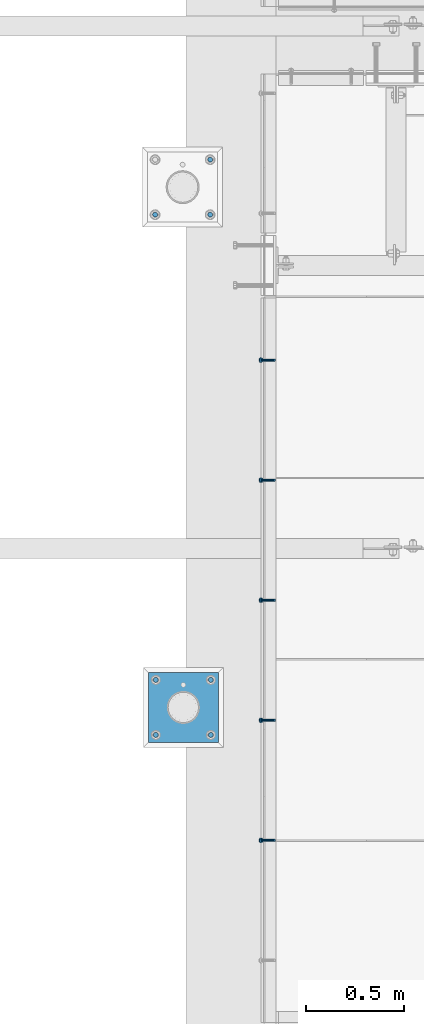
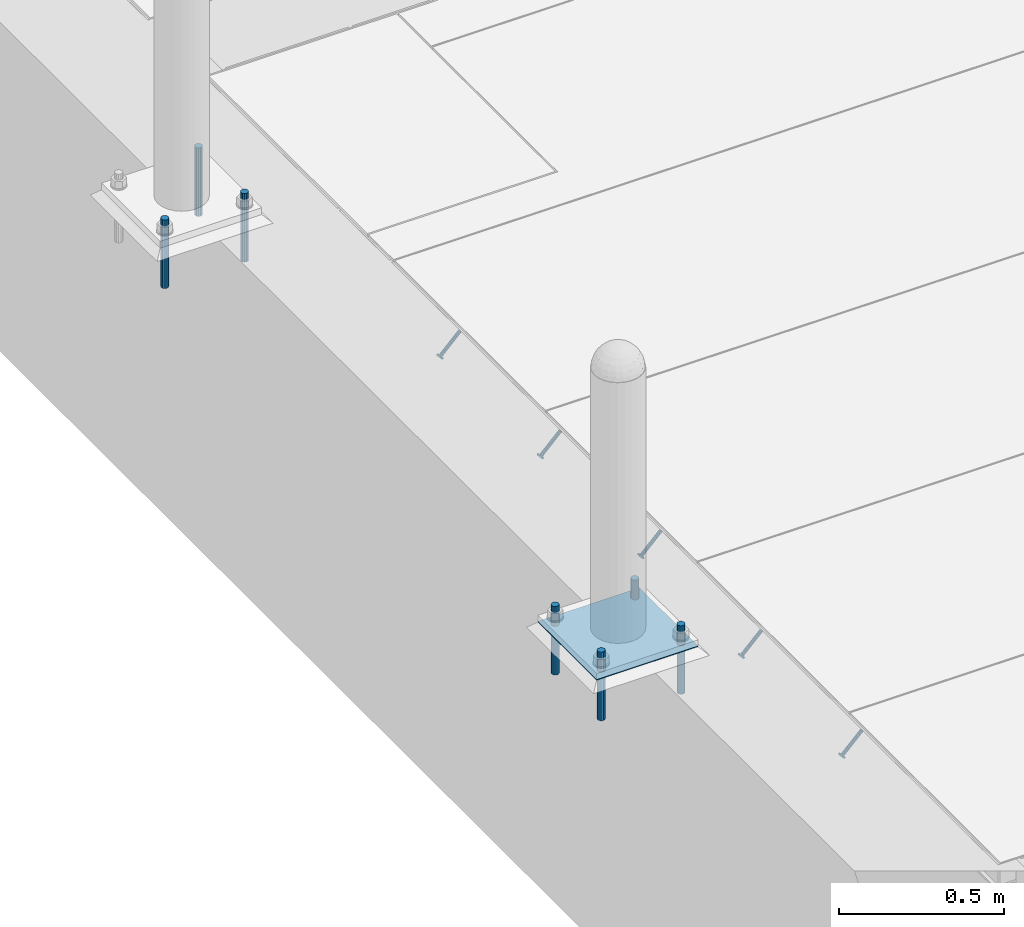
# One storey, part 2005 of 3843: 8 beams, 5 members, 3 elements without a shape of their own.
"""IFC2X3 building model written with IfcOpenShell, lengths in millimetres."""

from ifc_helpers import new_model, si_unit, frame, origin_with_axes, place, context, subcontext, project, spatial, faceted_brep, material, type_object, element, aggregate, save


model = new_model("IFC2X3")

# Units and contexts
model_context = context("Model", 3, precision=1e-05, world=origin_with_axes())
body_context = subcontext(model_context, "Body", "Model", "MODEL_VIEW")
ifc_project = project(units=[si_unit("LENGTHUNIT", "METRE", prefix="MILLI"), si_unit("AREAUNIT", "SQUARE_METRE"), si_unit("VOLUMEUNIT", "CUBIC_METRE"), si_unit("MASSUNIT", "GRAM", prefix="KILO"), si_unit("TIMEUNIT", "SECOND"), si_unit("PLANEANGLEUNIT", "RADIAN"), si_unit("SOLIDANGLEUNIT", "STERADIAN"), si_unit("THERMODYNAMICTEMPERATUREUNIT", "DEGREE_CELSIUS"), si_unit("LUMINOUSINTENSITYUNIT", "LUMEN")], contexts=[model_context])

# Site, building, storey
site_placement = place(None, origin_with_axes())
site = spatial("IfcSite", under=ifc_project, at=site_placement, CompositionType="ELEMENT")
building_placement = place(site_placement, origin_with_axes())
building = spatial("IfcBuilding", under=site, at=building_placement, Name="Undefined", CompositionType="ELEMENT")
storey_placement = place(building_placement, origin_with_axes())
storey = spatial("IfcBuildingStorey", under=building, at=storey_placement, Name="Undefined", CompositionType="ELEMENT", Elevation=0.0)

# Assembly, members
assembly_1_placement = place(storey_placement, origin_with_axes())
assembly_1 = element("IfcElementAssembly", 1, at=assembly_1_placement, inside=storey, Name="ANGLE", AssemblyPlace="NOTDEFINED", PredefinedType="RIGID_FRAME")
ifc_material_1 = material(Name="STEEL/A108")
member_type = type_object("IfcMemberType", PredefinedType="NOTDEFINED")
member_1_placement = place(assembly_1_placement, frame((41411.525, 16171.8625, 30397.4500030518), z_axis=(0.0, -1.0, 0.0), x_axis=(-0.707106781186548, 0.0, -0.707106781186548)))
member_1 = element("IfcMember", 2, at=member_1_placement, type_object=member_type, material=ifc_material_1, Name="HEADED STUD ANCHOR", context=body_context, shape_type="Brep", body=[
    faceted_brep([(7.27595761418343e-12, -3.18000006675175, 5.5), (0.0, -5.49999999998363, 3.1800000667572), (94.4879985803855, -5.50000000011278, 3.1800000667572), (94.4879985803782, -3.18000006687362, 5.5), (0.0, -6.3499999046162, 0.0), (94.4879985803855, -6.34999990474535, 0.0), (0.0, -5.49999999998363, -3.1800000667572), (94.4879985803855, -5.50000000011278, -3.1800000667572), (7.27595761418343e-12, -3.18000006675175, -5.5), (94.4879985803782, -3.18000006687362, -5.5), (7.27595761418343e-12, -1.81898940354586e-12, -6.34999990463257), (94.4879985803782, -1.20053300634027e-10, -6.34999990463257), (0.0, 3.18000006675175, -5.5), (94.4879985803709, 3.18000006663351, -5.5), (7.27595761418343e-12, 5.49999999998363, -3.1800000667572), (94.4879985803709, 5.49999999987267, -3.1800000667572), (7.27595761418343e-12, 6.3499999046162, 0.0), (94.4879985803673, 6.34999990450706, 0.0), (7.27595761418343e-12, 5.49999999998363, 3.1800000667572), (94.4879985803709, 5.49999999987267, 3.1800000667572), (0.0, 3.18000006675175, 5.5), (94.4879985803709, 3.18000006663351, 5.5), (7.27595761418343e-12, -1.81898940354586e-12, 6.34999990463257), (94.4879985803782, -1.20053300634027e-10, 6.34999990463257), (96.5199985498621, -10.9899997712273, 6.34999990463257), (96.5199985498548, -6.34000015270249, 10.9899997711182), (96.5199985498621, -12.6999998093743, 0.0), (96.5199985498621, -10.9899997712273, -6.34999990463257), (96.5199985498548, -6.34000015270249, -10.9899997711182), (96.5199985498475, -1.21872290037572e-10, -12.6899995803833), (96.5199985498402, 6.34000015245874, -10.9899997711182), (96.519998549833, 10.9899997709817, -6.34999990463257), (96.519998549833, 12.6999998091305, 0.0), (96.519998549833, 10.9899997709817, 6.34999990463257), (96.5199985498402, 6.34000015245874, 10.9899997711182), (96.5199985498475, -1.21872290037572e-10, 12.6899995803833), (101.599998473539, -10.9899997712328, 6.34999990463257), (101.599998473532, -6.34000015270976, 10.9899997711182), (101.599998473539, -12.6999998093797, 0.0), (101.599998473539, -10.9899997712328, -6.34999990463257), (101.599998473532, -6.34000015270976, -10.9899997711182), (101.599998473524, -1.29148247651756e-10, -12.6899995803833), (101.599998473517, 6.34000015245329, -10.9899997711182), (101.59999847351, 10.9899997709763, -6.34999990463257), (101.599998473503, 12.6999998091196, 0.0), (101.59999847351, 10.9899997709763, 6.34999990463257), (101.599998473517, 6.34000015245329, 10.9899997711182), (101.599998473524, -1.29148247651756e-10, 12.6899995803833)], [[[0, 1, 2, 3]], [[1, 4, 5, 2]], [[4, 6, 7, 5]], [[6, 8, 9, 7]], [[8, 10, 11, 9]], [[10, 12, 13, 11]], [[12, 14, 15, 13]], [[14, 16, 17, 15]], [[16, 18, 19, 17]], [[18, 20, 21, 19]], [[20, 22, 23, 21]], [[22, 0, 3, 23]], [[22, 20, 18, 16, 14, 12, 10, 8, 6, 4, 1, 0]], [[3, 2, 24, 25]], [[2, 5, 26, 24]], [[5, 7, 27, 26]], [[7, 9, 28, 27]], [[9, 11, 29, 28]], [[11, 13, 30, 29]], [[13, 15, 31, 30]], [[15, 17, 32, 31]], [[17, 19, 33, 32]], [[19, 21, 34, 33]], [[21, 23, 35, 34]], [[23, 3, 25, 35]], [[25, 24, 36, 37]], [[24, 26, 38, 36]], [[26, 27, 39, 38]], [[27, 28, 40, 39]], [[28, 29, 41, 40]], [[29, 30, 42, 41]], [[30, 31, 43, 42]], [[31, 32, 44, 43]], [[32, 33, 45, 44]], [[33, 34, 46, 45]], [[34, 35, 47, 46]], [[35, 25, 37, 47]], [[38, 39, 40, 41, 42, 43, 44, 45, 46, 47, 37, 36]]]),
])
member_2_placement = place(assembly_1_placement, frame((41411.525, 16781.4625, 30397.4500030518), z_axis=(0.0, -1.0, 0.0), x_axis=(-0.707106781186548, 0.0, -0.707106781186548)))
member_2 = element("IfcMember", 3, at=member_2_placement, type_object=member_type, material=ifc_material_1, Name="HEADED STUD ANCHOR", context=body_context, shape_type="Brep", body=[
    faceted_brep([(7.27595761418343e-12, -3.18000006675175, 5.5), (0.0, -5.49999999998363, 3.1800000667572), (94.4879985803855, -5.50000000011278, 3.1800000667572), (94.4879985803782, -3.18000006687362, 5.5), (0.0, -6.3499999046162, 0.0), (94.4879985803855, -6.34999990474535, 0.0), (0.0, -5.49999999998363, -3.1800000667572), (94.4879985803855, -5.50000000011278, -3.1800000667572), (7.27595761418343e-12, -3.18000006675175, -5.5), (94.4879985803782, -3.18000006687362, -5.5), (7.27595761418343e-12, -1.81898940354586e-12, -6.34999990463257), (94.4879985803782, -1.20053300634027e-10, -6.34999990463257), (0.0, 3.18000006675175, -5.5), (94.4879985803709, 3.18000006663351, -5.5), (7.27595761418343e-12, 5.49999999998363, -3.1800000667572), (94.4879985803709, 5.49999999987267, -3.1800000667572), (7.27595761418343e-12, 6.3499999046162, 0.0), (94.4879985803673, 6.34999990450706, 0.0), (7.27595761418343e-12, 5.49999999998363, 3.1800000667572), (94.4879985803709, 5.49999999987267, 3.1800000667572), (0.0, 3.18000006675175, 5.5), (94.4879985803709, 3.18000006663351, 5.5), (7.27595761418343e-12, -1.81898940354586e-12, 6.34999990463257), (94.4879985803782, -1.20053300634027e-10, 6.34999990463257), (96.5199985498621, -10.9899997712273, 6.34999990463257), (96.5199985498548, -6.34000015270249, 10.9899997711182), (96.5199985498621, -12.6999998093743, 0.0), (96.5199985498621, -10.9899997712273, -6.34999990463257), (96.5199985498548, -6.34000015270249, -10.9899997711182), (96.5199985498475, -1.21872290037572e-10, -12.6899995803833), (96.5199985498402, 6.34000015245874, -10.9899997711182), (96.519998549833, 10.9899997709817, -6.34999990463257), (96.519998549833, 12.6999998091305, 0.0), (96.519998549833, 10.9899997709817, 6.34999990463257), (96.5199985498402, 6.34000015245874, 10.9899997711182), (96.5199985498475, -1.21872290037572e-10, 12.6899995803833), (101.599998473539, -10.9899997712328, 6.34999990463257), (101.599998473532, -6.34000015270976, 10.9899997711182), (101.599998473539, -12.6999998093797, 0.0), (101.599998473539, -10.9899997712328, -6.34999990463257), (101.599998473532, -6.34000015270976, -10.9899997711182), (101.599998473524, -1.29148247651756e-10, -12.6899995803833), (101.599998473517, 6.34000015245329, -10.9899997711182), (101.59999847351, 10.9899997709763, -6.34999990463257), (101.599998473503, 12.6999998091196, 0.0), (101.59999847351, 10.9899997709763, 6.34999990463257), (101.599998473517, 6.34000015245329, 10.9899997711182), (101.599998473524, -1.29148247651756e-10, 12.6899995803833)], [[[0, 1, 2, 3]], [[1, 4, 5, 2]], [[4, 6, 7, 5]], [[6, 8, 9, 7]], [[8, 10, 11, 9]], [[10, 12, 13, 11]], [[12, 14, 15, 13]], [[14, 16, 17, 15]], [[16, 18, 19, 17]], [[18, 20, 21, 19]], [[20, 22, 23, 21]], [[22, 0, 3, 23]], [[22, 20, 18, 16, 14, 12, 10, 8, 6, 4, 1, 0]], [[3, 2, 24, 25]], [[2, 5, 26, 24]], [[5, 7, 27, 26]], [[7, 9, 28, 27]], [[9, 11, 29, 28]], [[11, 13, 30, 29]], [[13, 15, 31, 30]], [[15, 17, 32, 31]], [[17, 19, 33, 32]], [[19, 21, 34, 33]], [[21, 23, 35, 34]], [[23, 3, 25, 35]], [[25, 24, 36, 37]], [[24, 26, 38, 36]], [[26, 27, 39, 38]], [[27, 28, 40, 39]], [[28, 29, 41, 40]], [[29, 30, 42, 41]], [[30, 31, 43, 42]], [[31, 32, 44, 43]], [[32, 33, 45, 44]], [[33, 34, 46, 45]], [[34, 35, 47, 46]], [[35, 25, 37, 47]], [[38, 39, 40, 41, 42, 43, 44, 45, 46, 47, 37, 36]]]),
])
member_3_placement = place(assembly_1_placement, frame((41411.525, 17391.0625, 30397.4500030518), z_axis=(0.0, -1.0, 0.0), x_axis=(-0.707106781186548, 0.0, -0.707106781186548)))
member_3 = element("IfcMember", 4, at=member_3_placement, type_object=member_type, material=ifc_material_1, Name="HEADED STUD ANCHOR", context=body_context, shape_type="Brep", body=[
    faceted_brep([(7.27595761418343e-12, -3.18000006675175, 5.5), (0.0, -5.49999999998363, 3.1800000667572), (94.4879985803855, -5.50000000011278, 3.1800000667572), (94.4879985803782, -3.18000006687362, 5.5), (0.0, -6.3499999046162, 0.0), (94.4879985803855, -6.34999990474535, 0.0), (0.0, -5.49999999998363, -3.1800000667572), (94.4879985803855, -5.50000000011278, -3.1800000667572), (7.27595761418343e-12, -3.18000006675175, -5.5), (94.4879985803782, -3.18000006687362, -5.5), (7.27595761418343e-12, -1.81898940354586e-12, -6.34999990463257), (94.4879985803782, -1.20053300634027e-10, -6.34999990463257), (0.0, 3.18000006675175, -5.5), (94.4879985803709, 3.18000006663351, -5.5), (7.27595761418343e-12, 5.49999999998363, -3.1800000667572), (94.4879985803709, 5.49999999987267, -3.1800000667572), (7.27595761418343e-12, 6.3499999046162, 0.0), (94.4879985803673, 6.34999990450706, 0.0), (7.27595761418343e-12, 5.49999999998363, 3.1800000667572), (94.4879985803709, 5.49999999987267, 3.1800000667572), (0.0, 3.18000006675175, 5.5), (94.4879985803709, 3.18000006663351, 5.5), (7.27595761418343e-12, -1.81898940354586e-12, 6.34999990463257), (94.4879985803782, -1.20053300634027e-10, 6.34999990463257), (96.5199985498621, -10.9899997712273, 6.34999990463257), (96.5199985498548, -6.34000015270249, 10.9899997711182), (96.5199985498621, -12.6999998093743, 0.0), (96.5199985498621, -10.9899997712273, -6.34999990463257), (96.5199985498548, -6.34000015270249, -10.9899997711182), (96.5199985498475, -1.21872290037572e-10, -12.6899995803833), (96.5199985498402, 6.34000015245874, -10.9899997711182), (96.519998549833, 10.9899997709817, -6.34999990463257), (96.519998549833, 12.6999998091305, 0.0), (96.519998549833, 10.9899997709817, 6.34999990463257), (96.5199985498402, 6.34000015245874, 10.9899997711182), (96.5199985498475, -1.21872290037572e-10, 12.6899995803833), (101.599998473539, -10.9899997712328, 6.34999990463257), (101.599998473532, -6.34000015270976, 10.9899997711182), (101.599998473539, -12.6999998093797, 0.0), (101.599998473539, -10.9899997712328, -6.34999990463257), (101.599998473532, -6.34000015270976, -10.9899997711182), (101.599998473524, -1.29148247651756e-10, -12.6899995803833), (101.599998473517, 6.34000015245329, -10.9899997711182), (101.59999847351, 10.9899997709763, -6.34999990463257), (101.599998473503, 12.6999998091196, 0.0), (101.59999847351, 10.9899997709763, 6.34999990463257), (101.599998473517, 6.34000015245329, 10.9899997711182), (101.599998473524, -1.29148247651756e-10, 12.6899995803833)], [[[0, 1, 2, 3]], [[1, 4, 5, 2]], [[4, 6, 7, 5]], [[6, 8, 9, 7]], [[8, 10, 11, 9]], [[10, 12, 13, 11]], [[12, 14, 15, 13]], [[14, 16, 17, 15]], [[16, 18, 19, 17]], [[18, 20, 21, 19]], [[20, 22, 23, 21]], [[22, 0, 3, 23]], [[22, 20, 18, 16, 14, 12, 10, 8, 6, 4, 1, 0]], [[3, 2, 24, 25]], [[2, 5, 26, 24]], [[5, 7, 27, 26]], [[7, 9, 28, 27]], [[9, 11, 29, 28]], [[11, 13, 30, 29]], [[13, 15, 31, 30]], [[15, 17, 32, 31]], [[17, 19, 33, 32]], [[19, 21, 34, 33]], [[21, 23, 35, 34]], [[23, 3, 25, 35]], [[25, 24, 36, 37]], [[24, 26, 38, 36]], [[26, 27, 39, 38]], [[27, 28, 40, 39]], [[28, 29, 41, 40]], [[29, 30, 42, 41]], [[30, 31, 43, 42]], [[31, 32, 44, 43]], [[32, 33, 45, 44]], [[33, 34, 46, 45]], [[34, 35, 47, 46]], [[35, 25, 37, 47]], [[38, 39, 40, 41, 42, 43, 44, 45, 46, 47, 37, 36]]]),
])
member_4_placement = place(assembly_1_placement, frame((41411.525, 18000.6625, 30397.4500030518), z_axis=(0.0, -1.0, 0.0), x_axis=(-0.707106781186548, 0.0, -0.707106781186548)))
member_4 = element("IfcMember", 5, at=member_4_placement, type_object=member_type, material=ifc_material_1, Name="HEADED STUD ANCHOR", context=body_context, shape_type="Brep", body=[
    faceted_brep([(7.27595761418343e-12, -3.18000006675175, 5.5), (0.0, -5.49999999998363, 3.1800000667572), (94.4879985803855, -5.50000000011278, 3.1800000667572), (94.4879985803782, -3.18000006687362, 5.5), (0.0, -6.3499999046162, 0.0), (94.4879985803855, -6.34999990474535, 0.0), (0.0, -5.49999999998363, -3.1800000667572), (94.4879985803855, -5.50000000011278, -3.1800000667572), (7.27595761418343e-12, -3.18000006675175, -5.5), (94.4879985803782, -3.18000006687362, -5.5), (7.27595761418343e-12, -1.81898940354586e-12, -6.34999990463257), (94.4879985803782, -1.20053300634027e-10, -6.34999990463257), (0.0, 3.18000006675175, -5.5), (94.4879985803709, 3.18000006663351, -5.5), (7.27595761418343e-12, 5.49999999998363, -3.1800000667572), (94.4879985803709, 5.49999999987267, -3.1800000667572), (7.27595761418343e-12, 6.3499999046162, 0.0), (94.4879985803673, 6.34999990450706, 0.0), (7.27595761418343e-12, 5.49999999998363, 3.1800000667572), (94.4879985803709, 5.49999999987267, 3.1800000667572), (0.0, 3.18000006675175, 5.5), (94.4879985803709, 3.18000006663351, 5.5), (7.27595761418343e-12, -1.81898940354586e-12, 6.34999990463257), (94.4879985803782, -1.20053300634027e-10, 6.34999990463257), (96.5199985498621, -10.9899997712273, 6.34999990463257), (96.5199985498548, -6.34000015270249, 10.9899997711182), (96.5199985498621, -12.6999998093743, 0.0), (96.5199985498621, -10.9899997712273, -6.34999990463257), (96.5199985498548, -6.34000015270249, -10.9899997711182), (96.5199985498475, -1.21872290037572e-10, -12.6899995803833), (96.5199985498402, 6.34000015245874, -10.9899997711182), (96.519998549833, 10.9899997709817, -6.34999990463257), (96.519998549833, 12.6999998091305, 0.0), (96.519998549833, 10.9899997709817, 6.34999990463257), (96.5199985498402, 6.34000015245874, 10.9899997711182), (96.5199985498475, -1.21872290037572e-10, 12.6899995803833), (101.599998473539, -10.9899997712328, 6.34999990463257), (101.599998473532, -6.34000015270976, 10.9899997711182), (101.599998473539, -12.6999998093797, 0.0), (101.599998473539, -10.9899997712328, -6.34999990463257), (101.599998473532, -6.34000015270976, -10.9899997711182), (101.599998473524, -1.29148247651756e-10, -12.6899995803833), (101.599998473517, 6.34000015245329, -10.9899997711182), (101.59999847351, 10.9899997709763, -6.34999990463257), (101.599998473503, 12.6999998091196, 0.0), (101.59999847351, 10.9899997709763, 6.34999990463257), (101.599998473517, 6.34000015245329, 10.9899997711182), (101.599998473524, -1.29148247651756e-10, 12.6899995803833)], [[[0, 1, 2, 3]], [[1, 4, 5, 2]], [[4, 6, 7, 5]], [[6, 8, 9, 7]], [[8, 10, 11, 9]], [[10, 12, 13, 11]], [[12, 14, 15, 13]], [[14, 16, 17, 15]], [[16, 18, 19, 17]], [[18, 20, 21, 19]], [[20, 22, 23, 21]], [[22, 0, 3, 23]], [[22, 20, 18, 16, 14, 12, 10, 8, 6, 4, 1, 0]], [[3, 2, 24, 25]], [[2, 5, 26, 24]], [[5, 7, 27, 26]], [[7, 9, 28, 27]], [[9, 11, 29, 28]], [[11, 13, 30, 29]], [[13, 15, 31, 30]], [[15, 17, 32, 31]], [[17, 19, 33, 32]], [[19, 21, 34, 33]], [[21, 23, 35, 34]], [[23, 3, 25, 35]], [[25, 24, 36, 37]], [[24, 26, 38, 36]], [[26, 27, 39, 38]], [[27, 28, 40, 39]], [[28, 29, 41, 40]], [[29, 30, 42, 41]], [[30, 31, 43, 42]], [[31, 32, 44, 43]], [[32, 33, 45, 44]], [[33, 34, 46, 45]], [[34, 35, 47, 46]], [[35, 25, 37, 47]], [[38, 39, 40, 41, 42, 43, 44, 45, 46, 47, 37, 36]]]),
])
member_5_placement = place(assembly_1_placement, frame((41411.525, 18610.2625, 30397.4500030518), z_axis=(0.0, -1.0, 0.0), x_axis=(-0.707106781186548, 0.0, -0.707106781186548)))
member_5 = element("IfcMember", 6, at=member_5_placement, type_object=member_type, material=ifc_material_1, Name="HEADED STUD ANCHOR", context=body_context, shape_type="Brep", body=[
    faceted_brep([(7.27595761418343e-12, -3.18000006675175, 5.5), (0.0, -5.49999999998363, 3.1800000667572), (94.4879985803855, -5.50000000011278, 3.1800000667572), (94.4879985803782, -3.18000006687362, 5.5), (0.0, -6.3499999046162, 0.0), (94.4879985803855, -6.34999990474535, 0.0), (0.0, -5.49999999998363, -3.1800000667572), (94.4879985803855, -5.50000000011278, -3.1800000667572), (7.27595761418343e-12, -3.18000006675175, -5.5), (94.4879985803782, -3.18000006687362, -5.5), (7.27595761418343e-12, -1.81898940354586e-12, -6.34999990463257), (94.4879985803782, -1.20053300634027e-10, -6.34999990463257), (0.0, 3.18000006675175, -5.5), (94.4879985803709, 3.18000006663351, -5.5), (7.27595761418343e-12, 5.49999999998363, -3.1800000667572), (94.4879985803709, 5.49999999987267, -3.1800000667572), (7.27595761418343e-12, 6.3499999046162, 0.0), (94.4879985803673, 6.34999990450706, 0.0), (7.27595761418343e-12, 5.49999999998363, 3.1800000667572), (94.4879985803709, 5.49999999987267, 3.1800000667572), (0.0, 3.18000006675175, 5.5), (94.4879985803709, 3.18000006663351, 5.5), (7.27595761418343e-12, -1.81898940354586e-12, 6.34999990463257), (94.4879985803782, -1.20053300634027e-10, 6.34999990463257), (96.5199985498621, -10.9899997712273, 6.34999990463257), (96.5199985498548, -6.34000015270249, 10.9899997711182), (96.5199985498621, -12.6999998093743, 0.0), (96.5199985498621, -10.9899997712273, -6.34999990463257), (96.5199985498548, -6.34000015270249, -10.9899997711182), (96.5199985498475, -1.21872290037572e-10, -12.6899995803833), (96.5199985498402, 6.34000015245874, -10.9899997711182), (96.519998549833, 10.9899997709817, -6.34999990463257), (96.519998549833, 12.6999998091305, 0.0), (96.519998549833, 10.9899997709817, 6.34999990463257), (96.5199985498402, 6.34000015245874, 10.9899997711182), (96.5199985498475, -1.21872290037572e-10, 12.6899995803833), (101.599998473539, -10.9899997712328, 6.34999990463257), (101.599998473532, -6.34000015270976, 10.9899997711182), (101.599998473539, -12.6999998093797, 0.0), (101.599998473539, -10.9899997712328, -6.34999990463257), (101.599998473532, -6.34000015270976, -10.9899997711182), (101.599998473524, -1.29148247651756e-10, -12.6899995803833), (101.599998473517, 6.34000015245329, -10.9899997711182), (101.59999847351, 10.9899997709763, -6.34999990463257), (101.599998473503, 12.6999998091196, 0.0), (101.59999847351, 10.9899997709763, 6.34999990463257), (101.599998473517, 6.34000015245329, 10.9899997711182), (101.599998473524, -1.29148247651756e-10, 12.6899995803833)], [[[0, 1, 2, 3]], [[1, 4, 5, 2]], [[4, 6, 7, 5]], [[6, 8, 9, 7]], [[8, 10, 11, 9]], [[10, 12, 13, 11]], [[12, 14, 15, 13]], [[14, 16, 17, 15]], [[16, 18, 19, 17]], [[18, 20, 21, 19]], [[20, 22, 23, 21]], [[22, 0, 3, 23]], [[22, 20, 18, 16, 14, 12, 10, 8, 6, 4, 1, 0]], [[3, 2, 24, 25]], [[2, 5, 26, 24]], [[5, 7, 27, 26]], [[7, 9, 28, 27]], [[9, 11, 29, 28]], [[11, 13, 30, 29]], [[13, 15, 31, 30]], [[15, 17, 32, 31]], [[17, 19, 33, 32]], [[19, 21, 34, 33]], [[21, 23, 35, 34]], [[23, 3, 25, 35]], [[25, 24, 36, 37]], [[24, 26, 38, 36]], [[26, 27, 39, 38]], [[27, 28, 40, 39]], [[28, 29, 41, 40]], [[29, 30, 42, 41]], [[30, 31, 43, 42]], [[31, 32, 44, 43]], [[32, 33, 45, 44]], [[33, 34, 46, 45]], [[34, 35, 47, 46]], [[35, 25, 37, 47]], [[38, 39, 40, 41, 42, 43, 44, 45, 46, 47, 37, 36]]]),
])
aggregate(assembly_1, [member_1, member_2, member_3, member_4, member_5])

# Assembly, beams
assembly_2_placement = place(storey_placement, origin_with_axes())
assembly_2 = element("IfcElementAssembly", 7, at=assembly_2_placement, inside=storey, Name="TEMPLATE", AssemblyPlace="NOTDEFINED", PredefinedType="RIGID_FRAME")
ifc_material_2 = material(Name="STEEL/316 SS")
beam_type_1 = type_object("IfcBeamType", PredefinedType="NOTDEFINED")
beam_1_placement = place(assembly_2_placement, frame((41083.378314209, 19348.6527605797, 30581.6), z_axis=(1.0, 0.0, 0.0), x_axis=(0.0, 0.0, -1.0)))
beam_1 = element("IfcBeam", 8, at=beam_1_placement, type_object=beam_type_1, material=ifc_material_2, Name="ANCHOR_ROD", context=body_context, shape_type="Brep", body=[
    faceted_brep([(0.0, -12.6999999999971, 0.0), (0.0, -10.9985226280696, -6.34999999999854), (253.999, -10.9985226280696, -6.34999999999854), (253.999, -12.6999999999971, 0.0), (0.0, -6.35000000000582, -10.9985226280623), (253.999, -6.35000000000582, -10.9985226280623), (0.0, 0.0, -12.6999999999971), (253.999, 0.0, -12.6999999999971), (0.0, 6.35000000000582, -10.9985226280623), (253.999, 6.35000000000582, -10.9985226280623), (0.0, 10.9985226280696, -6.34999999999854), (253.999, 10.9985226280696, -6.34999999999854), (0.0, 12.6999999999971, 0.0), (253.999, 12.6999999999971, 0.0), (0.0, 10.9985226280696, 6.34999999999854), (253.999, 10.9985226280696, 6.34999999999854), (0.0, 6.35000000000582, 10.9985226280623), (253.999, 6.35000000000582, 10.9985226280623), (0.0, 0.0, 12.6999999999971), (253.999, 0.0, 12.6999999999971), (0.0, -6.35000000000582, 10.9985226280623), (253.999, -6.35000000000582, 10.9985226280623), (0.0, -10.9985226280696, 6.34999999999854), (253.999, -10.9985226280696, 6.34999999999854)], [[[0, 1, 2, 3]], [[1, 4, 5, 2]], [[4, 6, 7, 5]], [[6, 8, 9, 7]], [[8, 10, 11, 9]], [[10, 12, 13, 11]], [[12, 14, 15, 13]], [[14, 16, 17, 15]], [[16, 18, 19, 17]], [[18, 20, 21, 19]], [[20, 22, 23, 21]], [[22, 0, 3, 23]], [[5, 7, 9, 11, 13, 15, 17, 19, 21, 23, 3, 2]], [[22, 20, 18, 16, 14, 12, 10, 8, 6, 4, 1, 0]]]),
])
beam_2_placement = place(assembly_2_placement, frame((41083.378314209, 19628.0527605797, 30581.6), z_axis=(-1.0, 0.0, 0.0), x_axis=(0.0, 0.0, -1.0)))
beam_2 = element("IfcBeam", 9, at=beam_2_placement, type_object=beam_type_1, material=ifc_material_2, Name="ANCHOR_ROD", context=body_context, shape_type="Brep", body=[
    faceted_brep([(0.0, -12.6999999999971, 0.0), (0.0, -10.9985226280696, -6.34999999999854), (253.999, -10.9985226280696, -6.34999999999854), (253.999, -12.6999999999971, 0.0), (0.0, -6.35000000000582, -10.9985226280623), (253.999, -6.35000000000582, -10.9985226280623), (0.0, 0.0, -12.6999999999971), (253.999, 0.0, -12.6999999999971), (0.0, 6.35000000000582, -10.9985226280623), (253.999, 6.35000000000582, -10.9985226280623), (0.0, 10.9985226280696, -6.34999999999854), (253.999, 10.9985226280696, -6.34999999999854), (0.0, 12.6999999999971, 0.0), (253.999, 12.6999999999971, 0.0), (0.0, 10.9985226280696, 6.34999999999854), (253.999, 10.9985226280696, 6.34999999999854), (0.0, 6.35000000000582, 10.9985226280623), (253.999, 6.35000000000582, 10.9985226280623), (0.0, 0.0, 12.6999999999971), (253.999, 0.0, 12.6999999999971), (0.0, -6.35000000000582, 10.9985226280623), (253.999, -6.35000000000582, 10.9985226280623), (0.0, -10.9985226280696, 6.34999999999854), (253.999, -10.9985226280696, 6.34999999999854)], [[[0, 1, 2, 3]], [[1, 4, 5, 2]], [[4, 6, 7, 5]], [[6, 8, 9, 7]], [[8, 10, 11, 9]], [[10, 12, 13, 11]], [[12, 14, 15, 13]], [[14, 16, 17, 15]], [[16, 18, 19, 17]], [[18, 20, 21, 19]], [[20, 22, 23, 21]], [[22, 0, 3, 23]], [[5, 7, 9, 11, 13, 15, 17, 19, 21, 23, 3, 2]], [[22, 20, 18, 16, 14, 12, 10, 8, 6, 4, 1, 0]]]),
])
beam_3_placement = place(assembly_2_placement, frame((40803.978314209, 19348.6527605797, 30581.6), z_axis=(1.0, 0.0, 0.0), x_axis=(0.0, 0.0, -1.0)))
beam_3 = element("IfcBeam", 10, at=beam_3_placement, type_object=beam_type_1, material=ifc_material_2, Name="ANCHOR_ROD", context=body_context, shape_type="Brep", body=[
    faceted_brep([(0.0, -12.6999999999971, 0.0), (0.0, -10.9985226280696, -6.34999999999854), (253.999, -10.9985226280696, -6.34999999999854), (253.999, -12.6999999999971, 0.0), (0.0, -6.35000000000582, -10.9985226280623), (253.999, -6.35000000000582, -10.9985226280623), (0.0, 0.0, -12.6999999999971), (253.999, 0.0, -12.6999999999971), (0.0, 6.35000000000582, -10.9985226280623), (253.999, 6.35000000000582, -10.9985226280623), (0.0, 10.9985226280696, -6.34999999999854), (253.999, 10.9985226280696, -6.34999999999854), (0.0, 12.6999999999971, 0.0), (253.999, 12.6999999999971, 0.0), (0.0, 10.9985226280696, 6.34999999999854), (253.999, 10.9985226280696, 6.34999999999854), (0.0, 6.35000000000582, 10.9985226280623), (253.999, 6.35000000000582, 10.9985226280623), (0.0, 0.0, 12.6999999999971), (253.999, 0.0, 12.6999999999971), (0.0, -6.35000000000582, 10.9985226280623), (253.999, -6.35000000000582, 10.9985226280623), (0.0, -10.9985226280696, 6.34999999999854), (253.999, -10.9985226280696, 6.34999999999854)], [[[0, 1, 2, 3]], [[1, 4, 5, 2]], [[4, 6, 7, 5]], [[6, 8, 9, 7]], [[8, 10, 11, 9]], [[10, 12, 13, 11]], [[12, 14, 15, 13]], [[14, 16, 17, 15]], [[16, 18, 19, 17]], [[18, 20, 21, 19]], [[20, 22, 23, 21]], [[22, 0, 3, 23]], [[5, 7, 9, 11, 13, 15, 17, 19, 21, 23, 3, 2]], [[22, 20, 18, 16, 14, 12, 10, 8, 6, 4, 1, 0]]]),
])
aggregate(assembly_2, [beam_1, beam_2, beam_3])

assembly_3_placement = place(storey_placement, origin_with_axes())
assembly_3 = element("IfcElementAssembly", 11, at=assembly_3_placement, inside=storey, Name="TEMPLATE", AssemblyPlace="NOTDEFINED", PredefinedType="RIGID_FRAME")
beam_4_placement = place(assembly_3_placement, frame((41086.9793884277, 16707.0092364098, 30581.6), z_axis=(1.0, 0.0, 0.0), x_axis=(0.0, 0.0, -1.0)))
beam_4 = element("IfcBeam", 12, at=beam_4_placement, type_object=beam_type_1, material=ifc_material_2, Name="ANCHOR_ROD", context=body_context, shape_type="Brep", body=[
    faceted_brep([(0.0, -12.6999999999971, 0.0), (0.0, -10.9985226280696, -6.34999999999854), (253.999, -10.9985226280696, -6.34999999999854), (253.999, -12.6999999999971, 0.0), (0.0, -6.35000000000582, -10.9985226280623), (253.999, -6.35000000000582, -10.9985226280623), (0.0, 0.0, -12.6999999999971), (253.999, 0.0, -12.6999999999971), (0.0, 6.35000000000582, -10.9985226280623), (253.999, 6.35000000000582, -10.9985226280623), (0.0, 10.9985226280696, -6.34999999999854), (253.999, 10.9985226280696, -6.34999999999854), (0.0, 12.6999999999971, 0.0), (253.999, 12.6999999999971, 0.0), (0.0, 10.9985226280696, 6.34999999999854), (253.999, 10.9985226280696, 6.34999999999854), (0.0, 6.35000000000582, 10.9985226280623), (253.999, 6.35000000000582, 10.9985226280623), (0.0, 0.0, 12.6999999999971), (253.999, 0.0, 12.6999999999971), (0.0, -6.35000000000582, 10.9985226280623), (253.999, -6.35000000000582, 10.9985226280623), (0.0, -10.9985226280696, 6.34999999999854), (253.999, -10.9985226280696, 6.34999999999854)], [[[0, 1, 2, 3]], [[1, 4, 5, 2]], [[4, 6, 7, 5]], [[6, 8, 9, 7]], [[8, 10, 11, 9]], [[10, 12, 13, 11]], [[12, 14, 15, 13]], [[14, 16, 17, 15]], [[16, 18, 19, 17]], [[18, 20, 21, 19]], [[20, 22, 23, 21]], [[22, 0, 3, 23]], [[5, 7, 9, 11, 13, 15, 17, 19, 21, 23, 3, 2]], [[22, 20, 18, 16, 14, 12, 10, 8, 6, 4, 1, 0]]]),
])
beam_5_placement = place(assembly_3_placement, frame((41086.9793884277, 16986.4092364098, 30581.6), z_axis=(-1.0, 0.0, 0.0), x_axis=(0.0, 0.0, -1.0)))
beam_5 = element("IfcBeam", 13, at=beam_5_placement, type_object=beam_type_1, material=ifc_material_2, Name="ANCHOR_ROD", context=body_context, shape_type="Brep", body=[
    faceted_brep([(0.0, -12.6999999999971, 0.0), (0.0, -10.9985226280696, -6.34999999999854), (253.999, -10.9985226280696, -6.34999999999854), (253.999, -12.6999999999971, 0.0), (0.0, -6.35000000000582, -10.9985226280623), (253.999, -6.35000000000582, -10.9985226280623), (0.0, 0.0, -12.6999999999971), (253.999, 0.0, -12.6999999999971), (0.0, 6.35000000000582, -10.9985226280623), (253.999, 6.35000000000582, -10.9985226280623), (0.0, 10.9985226280696, -6.34999999999854), (253.999, 10.9985226280696, -6.34999999999854), (0.0, 12.6999999999971, 0.0), (253.999, 12.6999999999971, 0.0), (0.0, 10.9985226280696, 6.34999999999854), (253.999, 10.9985226280696, 6.34999999999854), (0.0, 6.35000000000582, 10.9985226280623), (253.999, 6.35000000000582, 10.9985226280623), (0.0, 0.0, 12.6999999999971), (253.999, 0.0, 12.6999999999971), (0.0, -6.35000000000582, 10.9985226280623), (253.999, -6.35000000000582, 10.9985226280623), (0.0, -10.9985226280696, 6.34999999999854), (253.999, -10.9985226280696, 6.34999999999854)], [[[0, 1, 2, 3]], [[1, 4, 5, 2]], [[4, 6, 7, 5]], [[6, 8, 9, 7]], [[8, 10, 11, 9]], [[10, 12, 13, 11]], [[12, 14, 15, 13]], [[14, 16, 17, 15]], [[16, 18, 19, 17]], [[18, 20, 21, 19]], [[20, 22, 23, 21]], [[22, 0, 3, 23]], [[5, 7, 9, 11, 13, 15, 17, 19, 21, 23, 3, 2]], [[22, 20, 18, 16, 14, 12, 10, 8, 6, 4, 1, 0]]]),
])
beam_6_placement = place(assembly_3_placement, frame((40807.5793884277, 16707.0092364098, 30581.6), z_axis=(1.0, 0.0, 0.0), x_axis=(0.0, 0.0, -1.0)))
beam_6 = element("IfcBeam", 14, at=beam_6_placement, type_object=beam_type_1, material=ifc_material_2, Name="ANCHOR_ROD", context=body_context, shape_type="Brep", body=[
    faceted_brep([(0.0, -12.6999999999971, 0.0), (0.0, -10.9985226280696, -6.34999999999854), (253.999, -10.9985226280696, -6.34999999999854), (253.999, -12.6999999999971, 0.0), (0.0, -6.35000000000582, -10.9985226280623), (253.999, -6.35000000000582, -10.9985226280623), (0.0, 0.0, -12.6999999999971), (253.999, 0.0, -12.6999999999971), (0.0, 6.35000000000582, -10.9985226280623), (253.999, 6.35000000000582, -10.9985226280623), (0.0, 10.9985226280696, -6.34999999999854), (253.999, 10.9985226280696, -6.34999999999854), (0.0, 12.6999999999971, 0.0), (253.999, 12.6999999999971, 0.0), (0.0, 10.9985226280696, 6.34999999999854), (253.999, 10.9985226280696, 6.34999999999854), (0.0, 6.35000000000582, 10.9985226280623), (253.999, 6.35000000000582, 10.9985226280623), (0.0, 0.0, 12.6999999999971), (253.999, 0.0, 12.6999999999971), (0.0, -6.35000000000582, 10.9985226280623), (253.999, -6.35000000000582, 10.9985226280623), (0.0, -10.9985226280696, 6.34999999999854), (253.999, -10.9985226280696, 6.34999999999854)], [[[0, 1, 2, 3]], [[1, 4, 5, 2]], [[4, 6, 7, 5]], [[6, 8, 9, 7]], [[8, 10, 11, 9]], [[10, 12, 13, 11]], [[12, 14, 15, 13]], [[14, 16, 17, 15]], [[16, 18, 19, 17]], [[18, 20, 21, 19]], [[20, 22, 23, 21]], [[22, 0, 3, 23]], [[5, 7, 9, 11, 13, 15, 17, 19, 21, 23, 3, 2]], [[22, 20, 18, 16, 14, 12, 10, 8, 6, 4, 1, 0]]]),
])
beam_7_placement = place(assembly_3_placement, frame((40807.5793884277, 16986.4092364098, 30581.6), z_axis=(-1.0, 0.0, 0.0), x_axis=(0.0, 0.0, -1.0)))
beam_7 = element("IfcBeam", 15, at=beam_7_placement, type_object=beam_type_1, material=ifc_material_2, Name="ANCHOR_ROD", context=body_context, shape_type="Brep", body=[
    faceted_brep([(0.0, -12.6999999999971, 0.0), (0.0, -10.9985226280696, -6.34999999999854), (253.999, -10.9985226280696, -6.34999999999854), (253.999, -12.6999999999971, 0.0), (0.0, -6.35000000000582, -10.9985226280623), (253.999, -6.35000000000582, -10.9985226280623), (0.0, 0.0, -12.6999999999971), (253.999, 0.0, -12.6999999999971), (0.0, 6.35000000000582, -10.9985226280623), (253.999, 6.35000000000582, -10.9985226280623), (0.0, 10.9985226280696, -6.34999999999854), (253.999, 10.9985226280696, -6.34999999999854), (0.0, 12.6999999999971, 0.0), (253.999, 12.6999999999971, 0.0), (0.0, 10.9985226280696, 6.34999999999854), (253.999, 10.9985226280696, 6.34999999999854), (0.0, 6.35000000000582, 10.9985226280623), (253.999, 6.35000000000582, 10.9985226280623), (0.0, 0.0, 12.6999999999971), (253.999, 0.0, 12.6999999999971), (0.0, -6.35000000000582, 10.9985226280623), (253.999, -6.35000000000582, 10.9985226280623), (0.0, -10.9985226280696, 6.34999999999854), (253.999, -10.9985226280696, 6.34999999999854)], [[[0, 1, 2, 3]], [[1, 4, 5, 2]], [[4, 6, 7, 5]], [[6, 8, 9, 7]], [[8, 10, 11, 9]], [[10, 12, 13, 11]], [[12, 14, 15, 13]], [[14, 16, 17, 15]], [[16, 18, 19, 17]], [[18, 20, 21, 19]], [[20, 22, 23, 21]], [[22, 0, 3, 23]], [[5, 7, 9, 11, 13, 15, 17, 19, 21, 23, 3, 2]], [[22, 20, 18, 16, 14, 12, 10, 8, 6, 4, 1, 0]]]),
])
ifc_material_3 = material(Name="STEEL/A36")
beam_type_2 = type_object("IfcBeamType", PredefinedType="NOTDEFINED")
beam_8_placement = place(assembly_3_placement, frame((41125.0793884277, 16846.7092364098, 30506.9875), z_axis=(0.0, -1.0, 0.0), x_axis=(-1.0, 0.0, 0.0)))
beam_8 = element("IfcBeam", 16, at=beam_8_placement, type_object=beam_type_2, material=ifc_material_3, Name="TEMPLATE", context=body_context, shape_type="Brep", body=[
    faceted_brep([(0.0, 1.58750000000146, -177.800000000003), (0.0, 1.58750000000146, 177.800000000003), (355.600000000006, 1.58750000000146, 177.800000000003), (355.600000000006, 1.58750000000146, -177.800000000003), (0.0, -1.58750000000146, 177.800000000003), (355.600000000006, -1.58750000000146, 177.800000000003), (0.0, -1.58750000000146, -177.800000000003), (355.600000000006, -1.58750000000146, -177.800000000003)], [[[0, 1, 2, 3]], [[1, 4, 5, 2]], [[4, 6, 7, 5]], [[6, 0, 3, 7]], [[5, 7, 3, 2]], [[6, 4, 1, 0]]]),
])
aggregate(assembly_3, [beam_4, beam_5, beam_6, beam_7, beam_8])

save(model, "model.ifc")
